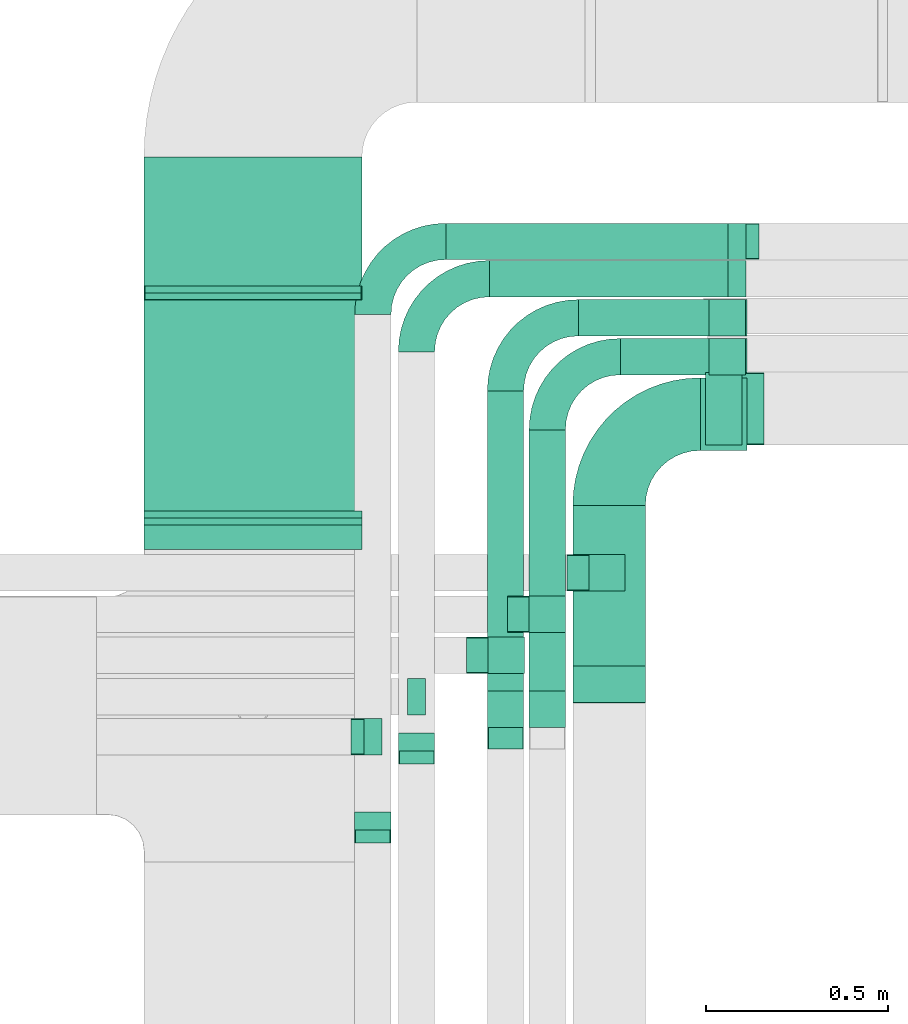
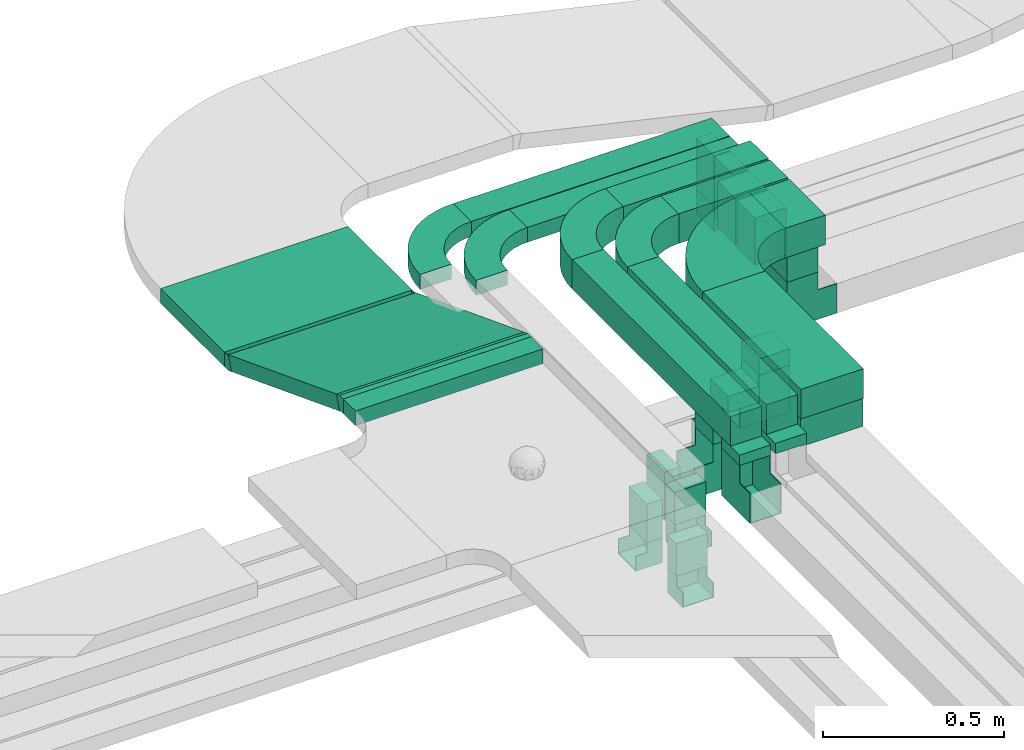
# One storey, part 11 of 38: 26 flow segments, 16 flow fittings.
"""IFC2X3 building model written with IfcOpenShell, lengths in millimetres."""

from ifc_helpers import new_model, entity, si_unit, converted_unit, derived_unit, direction, frame, frame_2d, origin, origin_2d_with_axis, place, context, subcontext, project, spatial, polyline, circle_curve, parameter, trimmed, segment, composite_curve, rectangle, outline, extrude, faceted_brep, source, transform, mapped, material, type_object, type_shapes, element, save


model = new_model("IFC2X3")

# Units and contexts
model_context = context("Model", 3, precision=0.01, world=origin(), true_north=direction((6.12303176911189e-17, 1.0)))
body_context = subcontext(model_context, "Body", "Model", "MODEL_VIEW")
ifc_project = project(units=[si_unit("LENGTHUNIT", "METRE", prefix="MILLI"), si_unit("AREAUNIT", "SQUARE_METRE"), si_unit("VOLUMEUNIT", "CUBIC_METRE"), converted_unit("PLANEANGLEUNIT", "DEGREE", entity("IfcRatioMeasure", 0.0174532925199433), si_unit("PLANEANGLEUNIT", "RADIAN"), dimensions=[0, 0, 0, 0, 0, 0, 0]), si_unit("MASSUNIT", "GRAM", prefix="KILO"), derived_unit("MASSDENSITYUNIT", [(si_unit("MASSUNIT", "GRAM", prefix="KILO"), 1), (si_unit("LENGTHUNIT", "METRE"), -3)]), derived_unit("MOMENTOFINERTIAUNIT", [(si_unit("LENGTHUNIT", "METRE"), 4)]), si_unit("TIMEUNIT", "SECOND"), si_unit("FREQUENCYUNIT", "HERTZ"), si_unit("THERMODYNAMICTEMPERATUREUNIT", "DEGREE_CELSIUS"), derived_unit("THERMALTRANSMITTANCEUNIT", [(si_unit("MASSUNIT", "GRAM", prefix="KILO"), 1), (si_unit("THERMODYNAMICTEMPERATUREUNIT", "KELVIN"), -1), (si_unit("TIMEUNIT", "SECOND"), -3)]), derived_unit("VOLUMETRICFLOWRATEUNIT", [(si_unit("LENGTHUNIT", "METRE"), 3), (si_unit("TIMEUNIT", "SECOND"), -1)]), derived_unit("MASSFLOWRATEUNIT", [(si_unit("MASSUNIT", "GRAM", prefix="KILO"), 1), (si_unit("TIMEUNIT", "SECOND"), -1)]), derived_unit("ROTATIONALFREQUENCYUNIT", [(si_unit("TIMEUNIT", "SECOND"), -1)]), si_unit("ELECTRICCURRENTUNIT", "AMPERE"), si_unit("ELECTRICVOLTAGEUNIT", "VOLT"), si_unit("POWERUNIT", "WATT"), si_unit("FORCEUNIT", "NEWTON", prefix="KILO"), si_unit("ILLUMINANCEUNIT", "LUX"), si_unit("LUMINOUSFLUXUNIT", "LUMEN"), si_unit("LUMINOUSINTENSITYUNIT", "CANDELA"), derived_unit("USERDEFINED", [(si_unit("MASSUNIT", "GRAM", prefix="KILO"), -1), (si_unit("LENGTHUNIT", "METRE"), -2), (si_unit("TIMEUNIT", "SECOND"), 3), (si_unit("LUMINOUSFLUXUNIT", "LUMEN"), 1)]), derived_unit("LINEARVELOCITYUNIT", [(si_unit("LENGTHUNIT", "METRE"), 1), (si_unit("TIMEUNIT", "SECOND"), -1)]), si_unit("PRESSUREUNIT", "PASCAL"), derived_unit("USERDEFINED", [(si_unit("LENGTHUNIT", "METRE"), -2), (si_unit("MASSUNIT", "GRAM", prefix="KILO"), 1), (si_unit("TIMEUNIT", "SECOND"), -2)]), derived_unit("LINEARFORCEUNIT", [(si_unit("MASSUNIT", "GRAM", prefix="KILO"), 1), (si_unit("LENGTHUNIT", "METRE"), 1), (si_unit("TIMEUNIT", "SECOND"), -2), (si_unit("LENGTHUNIT", "METRE"), -1)]), derived_unit("PLANARFORCEUNIT", [(si_unit("MASSUNIT", "GRAM", prefix="KILO"), 1), (si_unit("LENGTHUNIT", "METRE"), 1), (si_unit("TIMEUNIT", "SECOND"), -2), (si_unit("LENGTHUNIT", "METRE"), -2)])], contexts=[model_context])

# Site, building, storey
site_placement = place(None, frame((0.0, -0.00077364408347762, 0.0)))
site = spatial("IfcSite", under=ifc_project, at=site_placement, CompositionType="ELEMENT")
building_placement = place(site_placement, origin())
building = spatial("IfcBuilding", under=site, at=building_placement, CompositionType="ELEMENT")
storey_placement = place(building_placement, frame((0.0, 0.0, 4200.0)))
storey = spatial("IfcBuildingStorey", under=building, at=storey_placement, CompositionType="ELEMENT", Elevation=4200.0)

# Flow segments
cable_carrier_segment_type = type_object("IfcCableCarrierSegmentType", PredefinedType="CABLETRAYSEGMENT")
flow_segment_1_placement = place(storey_placement, frame((11383.5911506353, 10733.6547195084, 2975.0)))
element("IfcFlowSegment", 1, at=flow_segment_1_placement, inside=storey, type_object=cable_carrier_segment_type, context=body_context, shape_type="SweptSolid", body=[
    extrude(rectangle(XDim=544.131004135629, YDim=200.000000000002, at=frame_2d((0.0, 1.08713038571295e-12), x_axis=(1.0, 0.0))), frame((100.0, 272.065502067859, 0.0), z_axis=(0.0, 0.0, 1.0), x_axis=(0.0, -1.0, 0.0)), (0.0, 0.0, 1.0), 100.0),
])
flow_segment_2_placement = place(storey_placement, frame((11734.5911506353, 11428.7857236441, 2975.0)))
element("IfcFlowSegment", 2, at=flow_segment_2_placement, inside=storey, type_object=cable_carrier_segment_type, context=body_context, shape_type="SweptSolid", body=[
    extrude(rectangle(XDim=129.00000000001, YDim=200.000000000002, at=origin_2d_with_axis()), frame((64.5000000000027, 100.0, 0.0)), (0.0, 0.0, 1.0), 99.9999999999989),
])
flow_segment_3_placement = place(storey_placement, frame((11749.0911506353, 11443.7857236441, 2878.42931434907)))
element("IfcFlowSegment", 3, at=flow_segment_3_placement, inside=storey, type_object=cable_carrier_segment_type, context=body_context, shape_type="SweptSolid", body=[
    extrude(rectangle(XDim=199.999999999998, YDim=99.9999999999989, at=origin_2d_with_axis()), frame((50.0, 100.0, 0.0), z_axis=(0.0, 0.0, 1.0), x_axis=(0.0, -1.0, 0.0)), (0.0, 0.0, 1.0), 96.5706856509242),
])
flow_segment_4_placement = place(storey_placement, frame((10203.5911506353, 11156.3498749111, 3108.85255784625)))
element("IfcFlowSegment", 4, at=flow_segment_4_placement, inside=storey, type_object=cable_carrier_segment_type, context=body_context, shape_type="SweptSolid", body=[
    extrude(rectangle(XDim=67.4394769447223, YDim=600.000000000002, at=origin_2d_with_axis()), frame((300.0, 33.7197384723611, 0.0), z_axis=(0.0, 0.0, 1.0), x_axis=(0.0, 1.0, 0.0)), (0.0, 0.0, 1.0), 49.9999999999995),
])
flow_segment_5_placement = place(storey_placement, frame((10203.5911506353, 11244.2082924747, 2875.16285436756)))
element("IfcFlowSegment", 5, at=flow_segment_5_placement, inside=storey, type_object=cable_carrier_segment_type, context=body_context, shape_type="SweptSolid", body=[
    extrude(rectangle(XDim=49.9999999999996, YDim=641.534146168954, at=frame_2d((1.36424205265939e-12, -6.25277607468888e-13), x_axis=(0.0, 1.0))), frame((0.0, 308.421059635095, 138.292148925368), z_axis=(1.0, 0.0, 0.0), x_axis=(0.0, 0.933580426497194, -0.35836794954532)), (0.0, 0.0, 1.0), 600.000000000002),
])
flow_segment_6_placement = place(storey_placement, frame((10203.5911506353, 11881.4693523637, 2868.05744873961)))
element("IfcFlowSegment", 6, at=flow_segment_6_placement, inside=storey, type_object=cable_carrier_segment_type, context=body_context, shape_type="SweptSolid", body=[
    extrude(rectangle(XDim=354.579149652475, YDim=600.000000000002, at=origin_2d_with_axis()), frame((300.0, 177.289574826237, 0.0), z_axis=(0.0, 0.0, 1.0), x_axis=(0.0, -1.0, 0.0)), (0.0, 0.0, 1.0), 49.9999999999995),
])
flow_segment_7_placement = place(storey_placement, frame((11427.6386887966, 11042.3068384817, 2920.0)))
element("IfcFlowSegment", 7, at=flow_segment_7_placement, inside=storey, type_object=cable_carrier_segment_type, context=body_context, shape_type="SweptSolid", body=[
    extrude(rectangle(XDim=99.9999999999989, YDim=99.9999999999989, at=origin_2d_with_axis()), frame((50.0, 50.0, 0.0)), (0.0, 0.0, 1.0), 54.999999999903),
])
flow_segment_8_placement = place(storey_placement, frame((11383.5911506353, 10735.2304794999, 2880.0)))
element("IfcFlowSegment", 8, at=flow_segment_8_placement, inside=storey, type_object=cable_carrier_segment_type, context=body_context, shape_type="SweptSolid", body=[
    extrude(rectangle(XDim=200.000000000002, YDim=99.9999999999989, at=origin_2d_with_axis()), frame((100.0, 50.0, 0.0)), (0.0, 0.0, 1.0), 94.9999999996622),
])
flow_segment_9_placement = place(storey_placement, frame((11263.5911506353, 10716.8541189971, 2975.0)))
element("IfcFlowSegment", 9, at=flow_segment_9_placement, inside=storey, type_object=cable_carrier_segment_type, context=body_context, shape_type="SweptSolid", body=[
    extrude(rectangle(XDim=769.000000000009, YDim=99.9999999999989, at=frame_2d((1.08002495835535e-12, 0.0), x_axis=(1.0, 0.0))), frame((50.0, 384.500000000025, 0.0), z_axis=(0.0, 0.0, 1.0), x_axis=(0.0, -1.0, 0.0)), (0.0, 0.0, 1.0), 100.000000000001),
])
flow_segment_10_placement = place(storey_placement, frame((11514.5911506353, 11636.8541189971, 2975.0)))
element("IfcFlowSegment", 10, at=flow_segment_10_placement, inside=storey, type_object=cable_carrier_segment_type, context=body_context, shape_type="SweptSolid", body=[
    extrude(rectangle(XDim=349.000000000007, YDim=99.9999999999989, at=origin_2d_with_axis()), frame((174.500000000006, 50.0, 0.0)), (0.0, 0.0, 1.0), 100.000000000001),
])
flow_segment_11_placement = place(storey_placement, frame((11758.2838852019, 11636.854119063, 2815.22575139994)))
element("IfcFlowSegment", 11, at=flow_segment_11_placement, inside=storey, type_object=cable_carrier_segment_type, context=body_context, shape_type="SweptSolid", body=[
    extrude(rectangle(XDim=159.774248810582, YDim=99.9999998682313, at=frame_2d((-1.08357767203415e-12, 0.0), x_axis=(0.0, 1.0))), frame((0.00410107392755776, 50.0, 79.8871243000251), z_axis=(1.0, 0.0, 5.13358561742023e-05), x_axis=(0.0, -1.0, 0.0)), (0.0, 5.13358561742023e-05, 1.0), 99.9999999999989),
])
flow_segment_12_placement = place(storey_placement, frame((11263.5911506353, 10928.6547195084, 2920.0)))
element("IfcFlowSegment", 12, at=flow_segment_12_placement, inside=storey, type_object=cable_carrier_segment_type, context=body_context, shape_type="SweptSolid", body=[
    extrude(rectangle(XDim=99.9999999999989, YDim=99.9999999999989, at=origin_2d_with_axis()), frame((50.0, 50.0, 0.0), z_axis=(0.0, 0.0, 1.0), x_axis=(0.0, -1.0, 0.0)), (0.0, 0.0, 1.0), 54.9999999997298),
])
flow_segment_13_placement = place(storey_placement, frame((11399.5911506353, 11743.9581146252, 2975.0)))
element("IfcFlowSegment", 13, at=flow_segment_13_placement, inside=storey, type_object=cable_carrier_segment_type, context=body_context, shape_type="SweptSolid", body=[
    extrude(rectangle(XDim=464.000000000027, YDim=99.9999999999989, at=frame_2d((1.08002495835535e-12, 0.0), x_axis=(1.0, 0.0))), frame((232.0, 50.0, 0.0)), (0.0, 0.0, 1.0), 100.000000000001),
])
flow_segment_14_placement = place(storey_placement, frame((11758.5920056747, 11743.9581146252, 2818.4)))
element("IfcFlowSegment", 14, at=flow_segment_14_placement, inside=storey, type_object=cable_carrier_segment_type, context=body_context, shape_type="SweptSolid", body=[
    extrude(rectangle(XDim=99.9999999999989, YDim=99.9999999999989, at=origin_2d_with_axis()), frame((50.0, 50.0, 0.0), z_axis=(0.0, 0.0, 1.0), x_axis=(0.0, 1.0, 0.0)), (0.0, 0.0, 1.0), 156.599999999993),
])
flow_segment_15_placement = place(storey_placement, frame((11148.5911506353, 10716.8541189971, 2975.0)))
element("IfcFlowSegment", 15, at=flow_segment_15_placement, inside=storey, type_object=cable_carrier_segment_type, context=body_context, shape_type="SweptSolid", body=[
    extrude(rectangle(XDim=876.10399562814, YDim=99.9999999999989, at=frame_2d((1.08002495835535e-12, 0.0), x_axis=(1.0, 0.0))), frame((50.0, 438.05199781407, 0.0), z_axis=(0.0, 0.0, 1.0), x_axis=(0.0, -1.0, 0.0)), (0.0, 0.0, 1.0), 99.9999999999978),
])
flow_segment_16_placement = place(storey_placement, frame((11148.5911506353, 10667.0439614788, 2940.0)))
element("IfcFlowSegment", 16, at=flow_segment_16_placement, inside=storey, type_object=cable_carrier_segment_type, context=body_context, shape_type="SweptSolid", body=[
    extrude(rectangle(XDim=99.9999999999989, YDim=99.9999999999989, at=origin_2d_with_axis()), frame((50.0, 50.0, 0.0), z_axis=(0.0, 0.0, 1.0), x_axis=(-1.0, 0.0, 0.0)), (0.0, 0.0, 1.0), 34.9999999999931),
])
flow_segment_17_placement = place(storey_placement, frame((11263.5911506353, 10667.0439614788, 2939.59163867542)))
element("IfcFlowSegment", 17, at=flow_segment_17_placement, inside=storey, type_object=cable_carrier_segment_type, context=body_context, shape_type="SweptSolid", body=[
    extrude(rectangle(XDim=99.9999999999989, YDim=99.9999999999989, at=origin_2d_with_axis()), frame((50.0, 50.0, 0.0), z_axis=(0.0, 0.0, 1.0), x_axis=(-1.0, 0.0, 0.0)), (0.0, 0.0, 1.0), 35.408361324178),
])
flow_segment_18_placement = place(storey_placement, frame((11154.5911506353, 11851.5299176425, 2975.0)))
element("IfcFlowSegment", 18, at=flow_segment_18_placement, inside=storey, type_object=cable_carrier_segment_type, context=body_context, shape_type="SweptSolid", body=[
    extrude(rectangle(XDim=706.005050633869, YDim=99.9999999999989, at=origin_2d_with_axis()), frame((353.002525316935, 50.0, 0.0)), (0.0, 0.0, 1.0), 49.9999999999995),
])
flow_segment_19_placement = place(storey_placement, frame((11810.4915805971, 11851.5299176425, 2768.40000000001)))
element("IfcFlowSegment", 19, at=flow_segment_19_placement, inside=storey, type_object=cable_carrier_segment_type, context=body_context, shape_type="SweptSolid", body=[
    extrude(rectangle(XDim=50.0000000000016, YDim=99.9999999999989, at=origin_2d_with_axis()), frame((25.0, 50.0, 0.0), z_axis=(0.0, 0.0, 1.0), x_axis=(-1.0, 0.0, 0.0)), (0.0, 0.0, 1.0), 206.599999999987),
])
flow_segment_20_placement = place(storey_placement, frame((10903.5911506353, 10601.7140360315, 2865.0)))
element("IfcFlowSegment", 20, at=flow_segment_20_placement, inside=storey, type_object=cable_carrier_segment_type, context=body_context, shape_type="SweptSolid", body=[
    extrude(rectangle(XDim=50.0000000000016, YDim=99.9999999999989, at=origin_2d_with_axis()), frame((50.0, 25.0, 0.0), z_axis=(0.0, 0.0, 1.0), x_axis=(0.0, -1.0, 0.0)), (0.0, 0.0, 1.0), 110.000000000012),
])
flow_segment_21_placement = place(storey_placement, frame((11034.5911506353, 11954.0299176425, 2975.0)))
element("IfcFlowSegment", 21, at=flow_segment_21_placement, inside=storey, type_object=cable_carrier_segment_type, context=body_context, shape_type="SweptSolid", body=[
    extrude(rectangle(XDim=826.005050633864, YDim=99.9999999999989, at=origin_2d_with_axis()), frame((413.002525316932, 50.0, 0.0)), (0.0, 0.0, 1.0), 49.9999999999984),
])
flow_segment_22_placement = place(storey_placement, frame((11810.4915805971, 11954.0299176425, 2803.39999999997)))
element("IfcFlowSegment", 22, at=flow_segment_22_placement, inside=storey, type_object=cable_carrier_segment_type, context=body_context, shape_type="SweptSolid", body=[
    extrude(rectangle(XDim=50.0000000000016, YDim=99.9999999999989, at=origin_2d_with_axis()), frame((25.0, 50.0, 0.0), z_axis=(0.0, 0.0, 1.0), x_axis=(-1.0, 0.0, 0.0)), (0.0, 0.0, 1.0), 171.600000000021),
])
flow_segment_23_placement = place(storey_placement, frame((11150.7221647709, 10815.7857336441, 2920.0)))
element("IfcFlowSegment", 23, at=flow_segment_23_placement, inside=storey, type_object=cable_carrier_segment_type, context=body_context, shape_type="SweptSolid", body=[
    extrude(rectangle(XDim=99.9999999999989, YDim=99.9999999999989, at=origin_2d_with_axis()), frame((50.0, 50.0, 0.0), z_axis=(0.0, 0.0, 1.0), x_axis=(0.0, 1.0, 0.0)), (0.0, 0.0, 1.0), 54.9999999999951),
])
flow_segment_24_placement = place(storey_placement, frame((10928.5911506353, 10700.7857336441, 2810.0)))
element("IfcFlowSegment", 24, at=flow_segment_24_placement, inside=storey, type_object=cable_carrier_segment_type, context=body_context, shape_type="SweptSolid", body=[
    extrude(rectangle(XDim=99.9999999999989, YDim=50.0000000000016, at=origin_2d_with_axis()), frame((25.0, 50.0, 0.0), z_axis=(0.0, 0.0, 1.0), x_axis=(0.0, -1.0, 0.0)), (0.0, 0.0, 1.0), 165.000000000001),
])
flow_segment_25_placement = place(storey_placement, frame((10783.5911506353, 10384.1747700795, 2865.0)))
element("IfcFlowSegment", 25, at=flow_segment_25_placement, inside=storey, type_object=cable_carrier_segment_type, context=body_context, shape_type="SweptSolid", body=[
    extrude(rectangle(XDim=99.9999999999989, YDim=50.0000000000016, at=origin_2d_with_axis()), frame((50.0, 25.0, 0.0), z_axis=(0.0, 0.0, 1.0), x_axis=(-1.0, 0.0, 0.0)), (0.0, 0.0, 1.0), 110.000000000005),
])
flow_segment_26_placement = place(storey_placement, frame((10808.5911506353, 10590.7857336441, 2845.0)))
element("IfcFlowSegment", 26, at=flow_segment_26_placement, inside=storey, type_object=cable_carrier_segment_type, context=body_context, shape_type="SweptSolid", body=[
    extrude(rectangle(XDim=99.9999999999989, YDim=50.0000000000016, at=origin_2d_with_axis()), frame((25.0, 50.0, 0.0), z_axis=(0.0, 0.0, 1.0), x_axis=(0.0, 1.0, 0.0)), (0.0, 0.0, 1.0), 130.000000000003),
])

# Flow fittings
ifc_material = material()
cable_carrier_fitting_type_1 = type_object("IfcCableCarrierFittingType", Name="470_DKC_S5_Variable Angle Elbow 0-45:-", PredefinedType="NOTDEFINED", material=ifc_material)
shared_shape_1 = source(origin(), body_context, "Body", "SweptSolid", [
    extrude(outline(composite_curve([segment(polyline([(-125.750000000001, -225.25), (-124.749999999999, -225.25)]), True, "CONTINUOUS"), segment(trimmed(circle_curve(frame_2d((-124.75, 124.75), x_axis=(0.0, -1.0)), 350.0), [parameter(0.0)], [parameter(90.0000000000001)], True, "PARAMETER"), True, "CONTINUOUS"), segment(polyline([(225.25, 124.75), (225.25, 125.749999999999)]), True, "CONTINUOUS"), segment(polyline([(225.25, 125.749999999999), (25.25, 125.750000000001)]), True, "CONTINUOUS"), segment(polyline([(25.25, 125.750000000001), (25.25, 124.75)]), True, "CONTINUOUS"), segment(trimmed(circle_curve(frame_2d((-124.75, 124.75), x_axis=(0.0, -1.0)), 150.0), [parameter(0.0)], [parameter(90.0000000000001)], True, "PARAMETER"), False, "CONTINUOUS"), segment(polyline([(-124.749999999999, -25.2500000000003), (-125.750000000001, -25.2500000000003)]), True, "CONTINUOUS"), segment(polyline([(-125.750000000001, -25.2500000000003), (-125.750000000001, -225.25)]), True, "CONTINUOUS")], self_intersect=False)), frame((-125.249999999991, 125.249999999992, -50.0)), (0.0, 0.0, 1.0), 100.0),
])
type_shapes(cable_carrier_fitting_type_1, [shared_shape_1])
flow_fitting_1_placement = place(storey_placement, frame((11483.5911506353, 11528.7857236441, 3025.0), z_axis=(0.0, 0.0, 1.0), x_axis=(-1.0, 0.0, 0.0)))
element("IfcFlowFitting", 27, at=flow_fitting_1_placement, inside=storey, type_object=cable_carrier_fitting_type_1, material=ifc_material, Name="470_DKC_S5_Variable Angle Elbow 0-45:-", ObjectType="470_DKC_S5_Variable Angle Elbow 0-45:-", context=body_context, shape_type="MappedRepresentation", body=[
    mapped(shared_shape_1, transform((0.0, 0.0, 0.0), scale=1.0)),
])
cable_carrier_fitting_type_2 = type_object("IfcCableCarrierFittingType", Name="470_DKC_S5_Variable Angle Elbow 0-45:-", PredefinedType="NOTDEFINED", material=ifc_material)
shared_shape_2 = source(origin(), body_context, "Body", "SweptSolid", [
    extrude(outline(composite_curve([segment(polyline([(-100.749999999999, -150.250000000001), (-99.7499999999981, -150.250000000001)]), True, "CONTINUOUS"), segment(trimmed(circle_curve(frame_2d((-99.7500000000006, 99.7499999999987), x_axis=(0.0, -1.0)), 250.0), [parameter(0.0)], [parameter(90.0000000000001)], True, "PARAMETER"), True, "CONTINUOUS"), segment(polyline([(150.249999999999, 99.7500000000013), (150.249999999999, 100.750000000001)]), True, "CONTINUOUS"), segment(polyline([(150.249999999999, 100.750000000001), (50.2499999999992, 100.750000000001)]), True, "CONTINUOUS"), segment(polyline([(50.2499999999992, 100.750000000001), (50.2499999999992, 99.7500000000002)]), True, "CONTINUOUS"), segment(trimmed(circle_curve(frame_2d((-99.7500000000006, 99.7499999999987), x_axis=(0.0, -1.0)), 150.0), [parameter(0.0)], [parameter(90.0000000000001)], True, "PARAMETER"), False, "CONTINUOUS"), segment(polyline([(-99.7499999999989, -50.2500000000011), (-100.75, -50.2500000000011)]), True, "CONTINUOUS"), segment(polyline([(-100.75, -50.2500000000011), (-100.749999999999, -150.250000000001)]), True, "CONTINUOUS")], self_intersect=False)), frame((-100.249999999991, 100.249999999992, -50.0)), (0.0, 0.0, 1.0), 100.0),
])
type_shapes(cable_carrier_fitting_type_2, [shared_shape_2])
for number, where, z_axis, x_axis, name in (
    (28, (11313.5911506353, 11686.8541189971, 3025.0), (0.0, 0.0, 1.0), (-1.0, 0.0, 0.0), "470_DKC_S5_Variable Angle Elbow 0-45:-"),
    (29, (11198.5911506353, 11793.9581146252, 3025.0), (0.0, 0.0, 1.0), (-1.0, 0.0, 0.0), "470_DKC_S5_Variable Angle Elbow 0-45:-"),
):
    element("IfcFlowFitting", number, at=place(storey_placement, frame(where, z_axis=z_axis, x_axis=x_axis)), inside=storey, type_object=cable_carrier_fitting_type_2, material=ifc_material, Name=name, ObjectType="470_DKC_S5_Variable Angle Elbow 0-45:-", context=body_context, shape_type="MappedRepresentation", body=[
        mapped(shared_shape_2, transform((0.0, 0.0, 0.0), scale=1.0)),
    ])
cable_carrier_fitting_type_3 = type_object("IfcCableCarrierFittingType", Name="470_DKC_S5_Variable Angle Elbow 0-45:-", PredefinedType="NOTDEFINED", material=ifc_material)
shared_shape_3 = source(origin(), body_context, "Body", "SweptSolid", [
    extrude(outline(composite_curve([segment(polyline([(-100.750000000001, -150.25), (-99.7499999999994, -150.25)]), True, "CONTINUOUS"), segment(trimmed(circle_curve(frame_2d((-99.7499999999997, 99.7499999999995), x_axis=(0.0, -1.0)), 250.0), [parameter(0.0)], [parameter(90.0000000000001)], True, "PARAMETER"), True, "CONTINUOUS"), segment(polyline([(150.25, 99.75), (150.25, 100.749999999999)]), True, "CONTINUOUS"), segment(polyline([(150.25, 100.749999999999), (50.25, 100.75)]), True, "CONTINUOUS"), segment(polyline([(50.25, 100.75), (50.25, 99.7499999999998)]), True, "CONTINUOUS"), segment(trimmed(circle_curve(frame_2d((-99.7499999999997, 99.7499999999995), x_axis=(0.0, -1.0)), 150.0), [parameter(0.0)], [parameter(90.0000000000001)], True, "PARAMETER"), False, "CONTINUOUS"), segment(polyline([(-99.7499999999994, -50.2500000000003), (-100.750000000001, -50.2500000000003)]), True, "CONTINUOUS"), segment(polyline([(-100.750000000001, -50.2500000000003), (-100.750000000001, -150.25)]), True, "CONTINUOUS")], self_intersect=False)), frame((-100.249999999991, 100.249999999992, -25.0)), (0.0, 0.0, 1.0), 49.9999999999997),
])
type_shapes(cable_carrier_fitting_type_3, [shared_shape_3])
for number, where, z_axis, x_axis, name in (
    (30, (10953.5911506353, 11901.5299176425, 3000.0), (0.0, 0.0, 1.0), (-1.0, 0.0, 0.0), "470_DKC_S5_Variable Angle Elbow 0-45:-"),
    (31, (10833.5911506353, 12004.0299176425, 3000.0), (0.0, 0.0, 1.0), (-1.0, 0.0, 0.0), "470_DKC_S5_Variable Angle Elbow 0-45:-"),
):
    element("IfcFlowFitting", number, at=place(storey_placement, frame(where, z_axis=z_axis, x_axis=x_axis)), inside=storey, type_object=cable_carrier_fitting_type_3, material=ifc_material, Name=name, ObjectType="470_DKC_S5_Variable Angle Elbow 0-45:-", context=body_context, shape_type="MappedRepresentation", body=[
        mapped(shared_shape_3, transform((0.0, 0.0, 0.0), scale=1.0)),
    ])
cable_carrier_fitting_type_4 = type_object("IfcCableCarrierFittingType", PredefinedType="NOTDEFINED", material=ifc_material)
shared_shape_4 = source(origin(), body_context, "Body", "Brep", [
    faceted_brep([(-110.0, -50.0, 100.0), (-110.0, 50.0, 100.0), (-110.0, 50.0, 97.4600000101635), (-110.0, -47.4600000101596, 97.4600000101635), (-110.0, -47.4600000101596, -97.4600000101564), (-110.0, 50.0, -97.4600000101564), (-110.0, 50.0, -100.0), (-110.0, -50.0, -100.0), (50.0, 110.0, 100.0), (50.0, 110.0, -100.0), (-50.0, 110.0, -100.0), (-50.0, 110.0, -97.4600000101564), (47.460000010161, 110.0, -97.4600000101565), (47.460000010161, 110.0, 97.4600000101635), (-50.0, 110.0, 97.4600000101635), (-50.0, 110.0, 100.0), (50.0, -50.0, 100.0), (-50.0, 50.0, 100.0), (-50.0, 50.0, 97.4600000101635), (47.4600000101603, -47.4600000101602, 97.4600000101635), (47.4600000101603, -47.4600000101601, -97.4600000101564), (-50.0, 50.0, -97.4600000101564), (-50.0, 50.0, -100.0), (50.0, -50.0, -100.0)], [[[0, 1, 2, 3, 4, 5, 6, 7]], [[8, 9, 10, 11, 12, 13, 14, 15]], [[1, 0, 16, 8, 15, 17]], [[2, 1, 17, 18]], [[3, 2, 18, 14, 13, 19]], [[4, 3, 19, 20]], [[5, 4, 20, 12, 11, 21]], [[6, 5, 21, 22]], [[7, 6, 22, 10, 9, 23]], [[0, 7, 23, 16]], [[18, 17, 15, 14]], [[20, 19, 13, 12]], [[22, 21, 11, 10]], [[16, 23, 9, 8]]]),
])
type_shapes(cable_carrier_fitting_type_4, [shared_shape_4])
flow_fitting_2_placement = place(storey_placement, frame((11799.0911506353, 11543.7857236441, 2768.42931434907), z_axis=(0.0, 1.0, 0.0), x_axis=(-1.0, 0.0, 0.0)))
element("IfcFlowFitting", 32, at=flow_fitting_2_placement, inside=storey, type_object=cable_carrier_fitting_type_4, material=ifc_material, context=body_context, shape_type="MappedRepresentation", body=[
    mapped(shared_shape_4, transform((0.0, 0.0, 0.0), scale=1.0)),
])
cable_carrier_fitting_type_5 = type_object("IfcCableCarrierFittingType", PredefinedType="NOTDEFINED", material=ifc_material)
shared_shape_5 = source(origin(), body_context, "Body", "Brep", [
    faceted_brep([(-15.1936474712347, -25.0, 300.0), (-15.1936474712345, 25.0, 300.0), (-15.1936474712345, 25.0, 297.460000010164), (-15.1936474712347, -22.4600000101599, 297.460000010164), (-15.1936474712347, -22.4600000101599, -297.460000010156), (-15.1936474712345, 25.0, -297.460000010156), (-15.1936474712345, 25.0, -300.0), (-15.1936474712347, -25.0, -300.0), (23.1436906248771, -17.8945943720494, 300.0), (23.1436906248771, -17.8945943720494, -300.0), (5.2252931476111, 28.7844269528103, -300.0), (5.2252931476111, 28.7844269528103, -297.460000010156), (22.233436036673, -15.5233000982317, -297.460000010156), (22.233436036673, -15.5233000982317, 297.460000010164), (5.22529314761109, 28.7844269528103, 297.460000010164), (5.22529314761109, 28.7844269528103, 300.0), (4.63347612328901, -25.0, 300.0), (-4.63347612328824, 25.0, 300.0), (-4.63347612328824, 25.0, 297.460000010164), (4.16271495104584, -22.46000001016, 297.460000010164), (4.16271495104584, -22.46000001016, -297.460000010156), (-4.63347612328824, 25.0, -297.460000010156), (-4.63347612328824, 25.0, -300.0), (4.63347612328892, -25.0, -300.0)], [[[0, 1, 2, 3, 4, 5, 6, 7]], [[8, 9, 10, 11, 12, 13, 14, 15]], [[1, 0, 16, 8, 15, 17]], [[2, 1, 17, 18]], [[3, 2, 18, 14, 13, 19]], [[4, 3, 19, 20]], [[5, 4, 20, 12, 11, 21]], [[6, 5, 21, 22]], [[7, 6, 22, 10, 9, 23]], [[0, 7, 23, 16]], [[18, 17, 15, 14]], [[20, 19, 13, 12]], [[22, 21, 11, 10]], [[16, 23, 9, 8]]]),
])
type_shapes(cable_carrier_fitting_type_5, [shared_shape_5])
for number, where, z_axis, x_axis in (
    (33, (10503.5911506353, 11238.9829993271, 3133.85255784625), (-1.0, 0.0, 0.0), (0.0, 1.0, 0.0)),
    (34, (10503.5911506353, 11866.2757048925, 2893.05744873961), (-1.0, 0.0, 0.0), (0.0, -1.0, 0.0)),
):
    element("IfcFlowFitting", number, at=place(storey_placement, frame(where, z_axis=z_axis, x_axis=x_axis)), inside=storey, type_object=cable_carrier_fitting_type_5, material=ifc_material, context=body_context, shape_type="MappedRepresentation", body=[
        mapped(shared_shape_5, transform((0.0, 0.0, 0.0), scale=1.0)),
    ])
cable_carrier_fitting_type_6 = type_object("IfcCableCarrierFittingType", PredefinedType="NOTDEFINED", material=ifc_material)
shared_shape_6 = source(origin(), body_context, "Body", "Brep", [
    faceted_brep([(-110.0, -50.0, 50.0), (-110.0, 50.0, 50.0), (-110.0, 50.0, 47.4600000101635), (-110.0, -47.4600000101596, 47.4600000101635), (-110.0, -47.4600000101596, -47.4600000101565), (-110.0, 50.0, -47.4600000101565), (-110.0, 50.0, -50.0), (-110.0, -50.0, -50.0), (50.0, 110.0, 50.0), (50.0, 110.0, -50.0), (-50.0, 110.0, -50.0), (-50.0, 110.0, -47.4600000101565), (47.460000010161, 110.0, -47.4600000101565), (47.460000010161, 110.0, 47.4600000101635), (-50.0, 110.0, 47.4600000101635), (-50.0, 110.0, 50.0), (50.0, -50.0, 50.0), (-50.0, 50.0, 50.0), (-50.0, 50.0, 47.4600000101635), (47.4600000101603, -47.4600000101602, 47.4600000101635), (47.4600000101603, -47.4600000101601, -47.4600000101565), (-50.0, 50.0, -47.4600000101565), (-50.0, 50.0, -50.0), (50.0, -50.0, -50.0)], [[[0, 1, 2, 3, 4, 5, 6, 7]], [[8, 9, 10, 11, 12, 13, 14, 15]], [[1, 0, 16, 8, 15, 17]], [[2, 1, 17, 18]], [[3, 2, 18, 14, 13, 19]], [[4, 3, 19, 20]], [[5, 4, 20, 12, 11, 21]], [[6, 5, 21, 22]], [[7, 6, 22, 10, 9, 23]], [[0, 7, 23, 16]], [[18, 17, 15, 14]], [[20, 19, 13, 12]], [[22, 21, 11, 10]], [[16, 23, 9, 8]]]),
])
type_shapes(cable_carrier_fitting_type_6, [shared_shape_6])
for number, where, z_axis, x_axis in (
    (35, (11477.6386887966, 11092.3068384817, 2810.0), (0.0, -1.0, 0.0), (1.0, 0.0, 0.0)),
    (36, (11313.5911506353, 10978.6547195084, 2810.0), (0.0, -1.0, 0.0), (1.0, 0.0, 0.0)),
    (37, (11198.5911506353, 10717.0439614788, 2830.0), (1.0, 0.0, 0.0), (0.0, 1.0, 0.0)),
    (38, (11200.7221647709, 10865.7857336441, 2810.0), (0.0, 1.0, 0.0), (0.0, 0.0, -1.0)),
):
    element("IfcFlowFitting", number, at=place(storey_placement, frame(where, z_axis=z_axis, x_axis=x_axis)), inside=storey, type_object=cable_carrier_fitting_type_6, material=ifc_material, context=body_context, shape_type="MappedRepresentation", body=[
        mapped(shared_shape_6, transform((0.0, 0.0, 0.0), scale=1.0)),
    ])
cable_carrier_fitting_type_7 = type_object("IfcCableCarrierFittingType", PredefinedType="NOTDEFINED", material=ifc_material)
shared_shape_7 = source(origin(), body_context, "Body", "Brep", [
    faceted_brep([(-60.0, -25.0, 50.0), (-60.0, 25.0, 50.0), (-60.0, 25.0, 47.4600000101635), (-60.0, -22.4600000101598, 47.4600000101635), (-60.0, -22.4600000101598, -47.4600000101565), (-60.0, 25.0, -47.4600000101565), (-60.0, 25.0, -50.0), (-60.0, -25.0, -50.0), (25.0, 60.0, 50.0), (25.0, 60.0, -50.0), (-25.0, 60.0, -50.0), (-25.0, 60.0, -47.4600000101565), (22.4600000101609, 60.0, -47.4600000101565), (22.4600000101609, 60.0, 47.4600000101635), (-25.0, 60.0, 47.4600000101635), (-25.0, 60.0, 50.0), (25.0, -25.0, 50.0), (-25.0, 25.0, 50.0), (-25.0, 25.0, 47.4600000101635), (22.4600000101603, -22.4600000101601, 47.4600000101635), (22.4600000101603, -22.4600000101601, -47.4600000101565), (-25.0, 25.0, -47.4600000101565), (-25.0, 25.0, -50.0), (25.0, -25.0, -50.0)], [[[0, 1, 2, 3, 4, 5, 6, 7]], [[8, 9, 10, 11, 12, 13, 14, 15]], [[1, 0, 16, 8, 15, 17]], [[2, 1, 17, 18]], [[3, 2, 18, 14, 13, 19]], [[4, 3, 19, 20]], [[5, 4, 20, 12, 11, 21]], [[6, 5, 21, 22]], [[7, 6, 22, 10, 9, 23]], [[0, 7, 23, 16]], [[18, 17, 15, 14]], [[20, 19, 13, 12]], [[22, 21, 11, 10]], [[16, 23, 9, 8]]]),
])
type_shapes(cable_carrier_fitting_type_7, [shared_shape_7])
for number, where, z_axis, x_axis in (
    (39, (11835.4915805971, 12004.0299176425, 2743.39999999998), (0.0, 1.0, 0.0), (-1.0, 0.0, 0.0)),
    (40, (10833.5911506353, 10640.7857336441, 2785.0), (0.0, -1.0, 0.0), (1.0, 0.0, 0.0)),
    (41, (10953.5911506353, 10626.7140360315, 2805.0), (-1.0, 0.0, 0.0), (0.0, 0.0, -1.0)),
    (42, (10833.5911506353, 10409.1747700795, 2805.0), (-1.0, 0.0, 0.0), (0.0, 0.0, -1.0)),
):
    element("IfcFlowFitting", number, at=place(storey_placement, frame(where, z_axis=z_axis, x_axis=x_axis)), inside=storey, type_object=cable_carrier_fitting_type_7, material=ifc_material, context=body_context, shape_type="MappedRepresentation", body=[
        mapped(shared_shape_7, transform((0.0, 0.0, 0.0), scale=1.0)),
    ])

save(model, "model.ifc")
